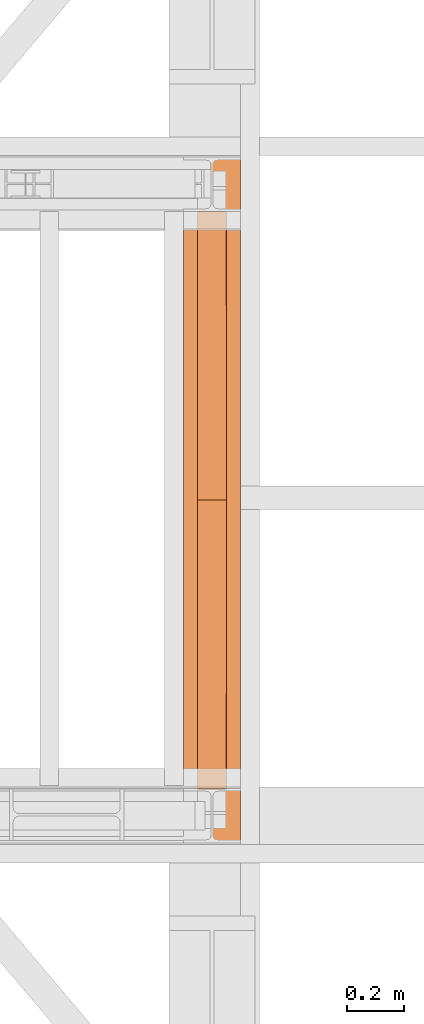
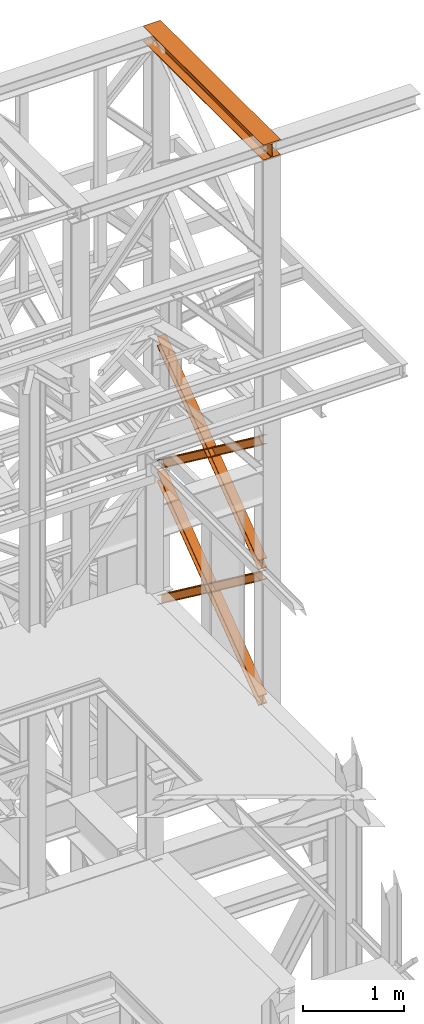
# One storey, part 183 of 208: 5 proxies.
"""IFC2X3 building model written with IfcOpenShell, lengths in millimetres."""

from ifc_helpers import new_model, entity, si_unit, converted_unit, frame, origin, origin_with_axes, place, context, subcontext, project, spatial, faceted_brep, element, save


model = new_model("IFC2X3")

# Units and contexts
model_context = context("Model", 3, precision=1e-05, world=origin())
plan_context = context("Plan", 3, precision=1e-05, world=origin())
body_context = subcontext(model_context, "Body", "Model", "MODEL_VIEW")
ifc_project = project(units=[si_unit("LENGTHUNIT", "METRE", prefix="MILLI"), converted_unit("PLANEANGLEUNIT", "DEGREE", entity("IfcPlaneAngleMeasure", 0.0174532925199433), si_unit("PLANEANGLEUNIT", "RADIAN"), dimensions=[0, 0, 0, 0, 0, 0, 0]), si_unit("AREAUNIT", "SQUARE_METRE"), si_unit("VOLUMEUNIT", "CUBIC_METRE")], contexts=[model_context, plan_context])

# Building, storey
building_placement = place(None, origin())
building = spatial("IfcBuilding", under=ifc_project, at=building_placement, CompositionType="COMPLEX")
storey_placement = place(building_placement, origin_with_axes())
storey = spatial("IfcBuildingStorey", under=building, at=storey_placement, Name="Geschoss", CompositionType="ELEMENT")

# Proxies
proxy_1_placement = place(storey_placement, frame((8693.25496703855, -16057.57439657638, 12249.99005869381), z_axis=(0.0, 0.0, 1.0), x_axis=(1.0, 0.0, 0.0)))
element("IfcBuildingElementProxy", 1, at=proxy_1_placement, inside=storey, context=body_context, shape_type="Brep", body=[
    faceted_brep([(0.00999999999839929, 2390.010012516977, 0.01000000000021828), (200.0100029802306, 2390.010012516977, 0.01000000000021828), (200.0100029802306, 2390.010012516977, 10.00999791383765), (121.2600035762771, 2390.010012516977, 10.01000536441825), (111.9441915473326, 2390.010012516977, 11.87455041170142), (105.1245498640819, 2390.010012516977, 18.69419349193595), (103.2600015571697, 2390.010012516977, 28.01000458955787), (103.2600015571697, 2390.010012516977, 162.0100153779986), (105.1245498640819, 2390.010012516977, 171.3258264756205), (111.9441915473326, 2390.010012516977, 178.145469555855), (121.2600035762771, 2390.010012516977, 180.0100146031382), (200.0100029802306, 2390.010012516977, 180.0100146031382), (200.0100029802306, 2390.010012516977, 190.0100125169756), (0.00999999999839929, 2390.010012516977, 190.0100125169756), (0.00999999999839929, 2390.010012516977, 180.0100146031382), (78.75999940395195, 2390.010012516977, 180.0100146031382), (88.07581143289644, 2390.010012516977, 178.145469555855), (94.89545311614711, 2390.010012516977, 171.3258264756205), (96.7600014230593, 2390.010012516977, 162.0100153779986), (96.7600014230593, 2390.010012516977, 28.01000458955787), (94.89545311614711, 2390.010012516977, 18.69419349193595), (88.07581143289644, 2390.010012516977, 11.87455041170142), (78.75999940395195, 2390.010012516977, 10.01000536441825), (0.00999999999839929, 2390.010012516977, 10.00999791383765), (200.0100029802306, 2390.010012516977, 0.01000000000021828), (0.00999999999839929, 2390.010012516977, 0.01000000000021828), (0.01000000000021828, 0.01000000000021828, 0.01000000000021828), (200.0100029802325, 0.01000000000021828, 0.01000000000021828), (200.0100029802306, 2390.010012516977, 10.00999791383765), (200.0100029802306, 2390.010012516977, 0.01000000000021828), (200.0100029802325, 0.01000000000021828, 0.01000000000021828), (200.0100029802325, 0.01000000000021828, 10.00999791383765), (121.2600035762771, 2390.010012516977, 10.01000536441825), (200.0100029802306, 2390.010012516977, 10.00999791383765), (200.0100029802325, 0.01000000000021828, 10.00999791383765), (121.2600035762789, 0.01000000000021828, 10.01000536441825), (111.9441915473326, 2390.010012516977, 11.87455041170142), (121.2600035762771, 2390.010012516977, 10.01000536441825), (121.2600035762789, 0.01000000000021828, 10.01000536441825), (111.9441915473344, 0.01000000000021828, 11.87455041170142), (105.1245498640819, 2390.010012516977, 18.69419349193595), (111.9441915473326, 2390.010012516977, 11.87455041170142), (111.9441915473344, 0.01000000000021828, 11.87455041170142), (105.1245498640838, 0.01000000000021828, 18.69419349193595), (103.2600015571697, 2390.010012516977, 28.01000458955787), (105.1245498640819, 2390.010012516977, 18.69419349193595), (105.1245498640838, 0.01000000000021828, 18.69419349193595), (103.2600015571716, 0.01000000000021828, 28.01000458955787), (103.2600015571697, 2390.010012516977, 162.0100153779986), (103.2600015571697, 2390.010012516977, 28.01000458955787), (103.2600015571716, 0.01000000000021828, 28.01000458955787), (103.2600015571716, 0.01000000000021828, 162.0100153779986), (105.1245498640819, 2390.010012516977, 171.3258264756205), (103.2600015571697, 2390.010012516977, 162.0100153779986), (103.2600015571716, 0.01000000000021828, 162.0100153779986), (105.1245498640838, 0.01000000000021828, 171.3258264756205), (111.9441915473326, 2390.010012516977, 178.145469555855), (105.1245498640819, 2390.010012516977, 171.3258264756205), (105.1245498640838, 0.01000000000021828, 171.3258264756205), (111.9441915473344, 0.01000000000021828, 178.145469555855), (121.2600035762771, 2390.010012516977, 180.0100146031382), (111.9441915473326, 2390.010012516977, 178.145469555855), (111.9441915473344, 0.01000000000021828, 178.145469555855), (121.2600035762789, 0.01000000000021828, 180.0100146031382), (200.0100029802306, 2390.010012516977, 180.0100146031382), (121.2600035762771, 2390.010012516977, 180.0100146031382), (121.2600035762789, 0.01000000000021828, 180.0100146031382), (200.0100029802325, 0.01000000000021828, 180.0100146031382), (200.0100029802306, 2390.010012516977, 190.0100125169756), (200.0100029802306, 2390.010012516977, 180.0100146031382), (200.0100029802325, 0.01000000000021828, 180.0100146031382), (200.0100029802325, 0.01000000000021828, 190.0100125169756), (0.00999999999839929, 2390.010012516977, 190.0100125169756), (200.0100029802306, 2390.010012516977, 190.0100125169756), (200.0100029802325, 0.01000000000021828, 190.0100125169756), (0.01000000000021828, 0.01000000000021828, 190.0100125169756), (0.00999999999839929, 2390.010012516977, 180.0100146031382), (0.00999999999839929, 2390.010012516977, 190.0100125169756), (0.01000000000021828, 0.01000000000021828, 190.0100125169756), (0.01000000000021828, 0.01000000000021828, 180.0100146031382), (78.75999940395195, 2390.010012516977, 180.0100146031382), (0.00999999999839929, 2390.010012516977, 180.0100146031382), (0.01000000000021828, 0.01000000000021828, 180.0100146031382), (78.75999940395377, 0.01000000000021828, 180.0100146031382), (88.07581143289644, 2390.010012516977, 178.145469555855), (78.75999940395195, 2390.010012516977, 180.0100146031382), (78.75999940395377, 0.01000000000021828, 180.0100146031382), (88.07581143289826, 0.01000000000021828, 178.145469555855), (94.89545311614711, 2390.010012516977, 171.3258264756205), (88.07581143289644, 2390.010012516977, 178.145469555855), (88.07581143289826, 0.01000000000021828, 178.145469555855), (94.89545311614893, 0.01000000000021828, 171.3258264756205), (96.7600014230593, 2390.010012516977, 162.0100153779986), (94.89545311614711, 2390.010012516977, 171.3258264756205), (94.89545311614893, 0.01000000000021828, 171.3258264756205), (96.76000142306111, 0.01000000000021828, 162.0100153779986), (96.7600014230593, 2390.010012516977, 28.01000458955787), (96.7600014230593, 2390.010012516977, 162.0100153779986), (96.76000142306111, 0.01000000000021828, 162.0100153779986), (96.76000142306111, 0.01000000000021828, 28.01000458955787), (94.89545311614711, 2390.010012516977, 18.69419349193595), (96.7600014230593, 2390.010012516977, 28.01000458955787), (96.76000142306111, 0.01000000000021828, 28.01000458955787), (94.89545311614893, 0.01000000000021828, 18.69419349193595), (88.07581143289644, 2390.010012516977, 11.87455041170142), (94.89545311614711, 2390.010012516977, 18.69419349193595), (94.89545311614893, 0.01000000000021828, 18.69419349193595), (88.07581143289826, 0.01000000000021828, 11.87455041170142), (78.75999940395195, 2390.010012516977, 10.01000536441825), (88.07581143289644, 2390.010012516977, 11.87455041170142), (88.07581143289826, 0.01000000000021828, 11.87455041170142), (78.75999940395377, 0.01000000000021828, 10.01000536441825), (0.00999999999839929, 2390.010012516977, 10.00999791383765), (78.75999940395195, 2390.010012516977, 10.01000536441825), (78.75999940395377, 0.01000000000021828, 10.01000536441825), (0.01000000000021828, 0.01000000000021828, 10.00999791383765), (0.00999999999839929, 2390.010012516977, 0.01000000000021828), (0.00999999999839929, 2390.010012516977, 10.00999791383765), (0.01000000000021828, 0.01000000000021828, 10.00999791383765), (0.01000000000021828, 0.01000000000021828, 0.01000000000021828), (0.01000000000021828, 0.01000000000021828, 0.01000000000021828), (0.01000000000021828, 0.01000000000021828, 10.00999791383765), (78.75999940395377, 0.01000000000021828, 10.01000536441825), (88.07581143289826, 0.01000000000021828, 11.87455041170142), (94.89545311614893, 0.01000000000021828, 18.69419349193595), (96.76000142306111, 0.01000000000021828, 28.01000458955787), (96.76000142306111, 0.01000000000021828, 162.0100153779986), (94.89545311614893, 0.01000000000021828, 171.3258264756205), (88.07581143289826, 0.01000000000021828, 178.145469555855), (78.75999940395377, 0.01000000000021828, 180.0100146031382), (0.01000000000021828, 0.01000000000021828, 180.0100146031382), (0.01000000000021828, 0.01000000000021828, 190.0100125169756), (200.0100029802325, 0.01000000000021828, 190.0100125169756), (200.0100029802325, 0.01000000000021828, 180.0100146031382), (121.2600035762789, 0.01000000000021828, 180.0100146031382), (111.9441915473344, 0.01000000000021828, 178.145469555855), (105.1245498640838, 0.01000000000021828, 171.3258264756205), (103.2600015571716, 0.01000000000021828, 162.0100153779986), (103.2600015571716, 0.01000000000021828, 28.01000458955787), (105.1245498640838, 0.01000000000021828, 18.69419349193595), (111.9441915473344, 0.01000000000021828, 11.87455041170142), (121.2600035762789, 0.01000000000021828, 10.01000536441825), (200.0100029802325, 0.01000000000021828, 10.00999791383765), (200.0100029802325, 0.01000000000021828, 0.01000000000021828)], [[[0, 1, 2, 3, 4, 5, 6, 7, 8, 9, 10, 11, 12, 13, 14, 15, 16, 17, 18, 19, 20, 21, 22, 23]], [[24, 25, 26, 27]], [[28, 29, 30, 31]], [[32, 33, 34, 35]], [[36, 37, 38, 39]], [[40, 41, 42, 43]], [[44, 45, 46, 47]], [[48, 49, 50, 51]], [[52, 53, 54, 55]], [[56, 57, 58, 59]], [[60, 61, 62, 63]], [[64, 65, 66, 67]], [[68, 69, 70, 71]], [[72, 73, 74, 75]], [[76, 77, 78, 79]], [[80, 81, 82, 83]], [[84, 85, 86, 87]], [[88, 89, 90, 91]], [[92, 93, 94, 95]], [[96, 97, 98, 99]], [[100, 101, 102, 103]], [[104, 105, 106, 107]], [[108, 109, 110, 111]], [[112, 113, 114, 115]], [[116, 117, 118, 119]], [[120, 121, 122, 123, 124, 125, 126, 127, 128, 129, 130, 131, 132, 133, 134, 135, 136, 137, 138, 139, 140, 141, 142, 143]]], orient=[[False], [False], [False], [False], [False], [False], [False], [False], [False], [False], [False], [False], [False], [False], [False], [False], [False], [False], [False], [False], [False], [False], [False], [False], [False], [False]]),
])
proxy_2_placement = place(storey_placement, frame((8743.082798491103, -15873.1965123697, 5499.689768811883), z_axis=(0.0, 0.0, 1.0), x_axis=(1.0, 0.0, 0.0)))
element("IfcBuildingElementProxy", 2, at=proxy_2_placement, inside=storey, context=body_context, shape_type="Brep", body=[
    faceted_brep([(100.0229428112289, 2015.632115793322, 1505.703241650141), (100.1858455764686, 1.953628280809426, 0.02100513656296243), (100.1847800613887, 1.791659257409265, 9.702984703128095), (100.0218641931642, 2015.632115793322, 1515.50632986583), (0.02294341679771605, 2015.632115793322, 1505.692236513578), (0.1858461820338562, 1.953628280809426, 0.01000000000021828), (100.1858455764686, 1.953628280809426, 0.02100513656296243), (100.0229428112289, 2015.632115793322, 1505.703241650141), (0.02186479873125791, 2015.632115793322, 1515.495324729271), (0.1847806669538841, 1.791659257407446, 9.691979566568989), (0.1858461820338562, 1.953628280809426, 0.01000000000021828), (0.02294341679771605, 2015.632115793322, 1505.692236513578), (47.52186451108355, 2015.632115793322, 1515.500552169136), (47.68478037930981, 1.791659257407446, 9.697207006434837), (0.1847806669538841, 1.791659257407446, 9.691979566568989), (0.02186479873125791, 2015.632115793322, 1515.495324729271), (47.51107833042624, 2015.632115793322, 1613.531434326045), (47.67412522851737, 0.1719690234003792, 106.517002672068), (47.68478037930981, 1.791659257407446, 9.697207006434837), (47.52186451108355, 2015.632115793322, 1515.500552169136), (0.01107861806849542, 2015.632115793322, 1613.526206886179), (0.174125516157801, 0.1719690234003792, 106.5117752322021), (47.67412522851737, 0.1719690234003792, 106.517002672068), (47.51107833042624, 2015.632115793322, 1613.531434326045), (0.01000000000021828, 2015.632115793322, 1623.329295101868), (0.1730600010778289, 0.01000000000021828, 116.1937547987636), (0.174125516157801, 0.1719690234003792, 106.5117752322021), (0.01107861806849542, 2015.632115793322, 1613.526206886179), (100.0099993944386, 2015.632115793322, 1623.340300238435), (100.1730593955126, 0.01000000000203727, 116.2047599353264), (0.1730600010778289, 0.01000000000021828, 116.1937547987636), (0.01000000000021828, 2015.632115793322, 1623.329295101868), (100.0110780125051, 2015.632115793322, 1613.537212022739), (100.1741249105908, 0.1719690234003792, 106.5227803687612), (100.1730593955126, 0.01000000000203727, 116.2047599353264), (100.0099993944386, 2015.632115793322, 1623.340300238435), (52.51107830014917, 2015.632115793322, 1613.531984582873), (52.67412519823665, 0.1719690234003792, 106.5175529288954), (100.1741249105908, 0.1719690234003792, 106.5227803687612), (100.0110780125051, 2015.632115793322, 1613.537212022739), (52.52186448080829, 2015.632115793322, 1515.501102425964), (52.68478034903274, 1.791659257409265, 9.697757263262247), (52.67412519823665, 0.1719690234003792, 106.5175529288954), (52.51107830014917, 2015.632115793322, 1613.531984582873), (100.0218641931642, 2015.632115793322, 1515.50632986583), (100.1847800613887, 1.791659257409265, 9.702984703128095), (52.68478034903274, 1.791659257409265, 9.697757263262247), (52.52186448080829, 2015.632115793322, 1515.501102425964), (100.1858455764686, 1.953628280809426, 0.02100513656296243), (0.1858461820338562, 1.953628280809426, 0.01000000000021828), (0.1847806669538841, 1.791659257407446, 9.691979566568989), (47.68478037930981, 1.791659257407446, 9.697207006434837), (47.67412522851737, 0.1719690234003792, 106.517002672068), (0.174125516157801, 0.1719690234003792, 106.5117752322021), (0.1730600010778289, 0.01000000000021828, 116.1937547987636), (100.1730593955126, 0.01000000000203727, 116.2047599353264), (100.1741249105908, 0.1719690234003792, 106.5227803687612), (52.67412519823665, 0.1719690234003792, 106.5175529288954), (52.68478034903274, 1.791659257409265, 9.697757263262247), (100.1847800613887, 1.791659257409265, 9.702984703128095), (100.0218641931642, 2015.632115793322, 1515.50632986583), (52.52186448080829, 2015.632115793322, 1515.501102425964), (52.51107830014917, 2015.632115793322, 1613.531984582873), (100.0110780125051, 2015.632115793322, 1613.537212022739), (100.0099993944386, 2015.632115793322, 1623.340300238435), (0.01000000000021828, 2015.632115793322, 1623.329295101868), (0.01107861806849542, 2015.632115793322, 1613.526206886179), (47.51107833042624, 2015.632115793322, 1613.531434326045), (47.52186451108355, 2015.632115793322, 1515.500552169136), (0.02186479873125791, 2015.632115793322, 1515.495324729271), (0.02294341679771605, 2015.632115793322, 1505.692236513578), (100.0229428112289, 2015.632115793322, 1505.703241650141)], [[[0, 1, 2, 3]], [[4, 5, 6, 7]], [[8, 9, 10, 11]], [[12, 13, 14, 15]], [[16, 17, 18, 19]], [[20, 21, 22, 23]], [[24, 25, 26, 27]], [[28, 29, 30, 31]], [[32, 33, 34, 35]], [[36, 37, 38, 39]], [[40, 41, 42, 43]], [[44, 45, 46, 47]], [[48, 49, 50, 51, 52, 53, 54, 55, 56, 57, 58, 59]], [[60, 61, 62, 63, 64, 65, 66, 67, 68, 69, 70, 71]]], orient=[[False], [False], [False], [False], [False], [False], [False], [False], [False], [False], [False], [False], [False], [False]]),
])
proxy_3_placement = place(storey_placement, frame((8743.082676642578, -15867.5743840594, 5504.219540188055), z_axis=(0.0, 0.0, 1.0), x_axis=(1.0, 0.0, 0.0)))
element("IfcBuildingElementProxy", 3, at=proxy_3_placement, inside=storey, context=body_context, shape_type="Brep", body=[
    faceted_brep([(100.0218596475406, 0.01000000000021828, 1511.076608371926), (100.1844513161013, 2010.009987483025, 9.820176864343011), (100.1855295209298, 2010.009987483025, 0.02100513655932446), (100.0229378523673, 0.01000000000021828, 1501.277436644132), (100.0229378523673, 0.01000000000021828, 1501.277436644132), (100.1855295209298, 2010.009987483025, 0.02100513655932446), (0.1855301264913578, 2010.009987483025, 0.01000000000021828), (0.02293845793246874, 0.01000000000021828, 1501.266431507576), (0.02293845793246874, 0.01000000000021828, 1501.266431507576), (0.1855301264913578, 2010.009987483025, 0.01000000000021828), (0.1844519216665503, 2010.009987483025, 9.809171727787543), (0.02186025310402329, 0.01000000000021828, 1511.06560323536), (0.02186025310402329, 0.01000000000021828, 1511.06560323536), (0.1844519216665503, 2010.009987483025, 9.809171727787543), (47.6844516340243, 2010.009987483025, 9.814399167646116), (47.52185996546359, 0.01000000000021828, 1511.070830675226), (47.52185996546359, 0.01000000000021828, 1511.070830675226), (47.6844516340243, 2010.009987483025, 9.814399167646116), (47.6736695857453, 2010.009987483025, 107.8061164454975), (47.51107791718459, 0.01000000000021828, 1609.062547953077), (47.51107791718459, 0.01000000000021828, 1609.062547953077), (47.6736695857453, 2010.009987483025, 107.8061164454975), (0.1736698733893718, 2010.009987483025, 107.8008890056317), (0.01107820482866373, 0.01000000000021828, 1609.057320513211), (0.01107820482866373, 0.01000000000021828, 1609.057320513211), (0.1736698733893718, 2010.009987483025, 107.8008890056317), (0.1725916685609263, 2010.009987483025, 117.6000607334227), (0.01000000000021828, 0.01000000000021828, 1618.856492240995), (0.01000000000021828, 0.01000000000021828, 1618.856492240995), (0.1725916685609263, 2010.009987483025, 117.6000607334227), (100.1725910629975, 2010.009987483025, 117.6110658699781), (100.009999394435, 0.01000000000021828, 1618.867497377558), (100.009999394435, 0.01000000000021828, 1618.867497377558), (100.1725910629975, 2010.009987483025, 117.6110658699781), (100.1736692678242, 2010.009987483025, 107.8118941421981), (100.0110775992634, 0.01000000000021828, 1609.068325649774), (100.0110775992634, 0.01000000000021828, 1609.068325649774), (100.1736692678242, 2010.009987483025, 107.8118941421981), (52.67366955546459, 2010.009987483025, 107.806666702325), (52.51107788690388, 0.01000000000021828, 1609.063098209905), (52.51107788690388, 0.01000000000021828, 1609.063098209905), (52.67366955546459, 2010.009987483025, 107.806666702325), (52.6844516037454, 2010.009987483025, 9.814949424477163), (52.52185993518287, 0.01000000000021828, 1511.071380932057), (52.52185993518287, 0.01000000000021828, 1511.071380932057), (52.6844516037454, 2010.009987483025, 9.814949424477163), (100.1844513161013, 2010.009987483025, 9.820176864343011), (100.0218596475406, 0.01000000000021828, 1511.076608371926), (100.1844513161013, 2010.009987483025, 9.820176864343011), (52.6844516037454, 2010.009987483025, 9.814949424477163), (52.67366955546459, 2010.009987483025, 107.806666702325), (100.1736692678242, 2010.009987483025, 107.8118941421981), (100.1725910629975, 2010.009987483025, 117.6110658699781), (0.1725916685609263, 2010.009987483025, 117.6000607334227), (0.1736698733893718, 2010.009987483025, 107.8008890056317), (47.6736695857453, 2010.009987483025, 107.8061164454975), (47.6844516340243, 2010.009987483025, 9.814399167646116), (0.1844519216665503, 2010.009987483025, 9.809171727787543), (0.1855301264913578, 2010.009987483025, 0.01000000000021828), (100.1855295209298, 2010.009987483025, 0.02100513655932446), (100.0229378523673, 0.01000000000021828, 1501.277436644132), (0.02293845793246874, 0.01000000000021828, 1501.266431507576), (0.02186025310402329, 0.01000000000021828, 1511.06560323536), (47.52185996546359, 0.01000000000021828, 1511.070830675226), (47.51107791718459, 0.01000000000021828, 1609.062547953077), (0.01107820482866373, 0.01000000000021828, 1609.057320513211), (0.01000000000021828, 0.01000000000021828, 1618.856492240995), (100.009999394435, 0.01000000000021828, 1618.867497377558), (100.0110775992634, 0.01000000000021828, 1609.068325649774), (52.51107788690388, 0.01000000000021828, 1609.063098209905), (52.52185993518287, 0.01000000000021828, 1511.071380932057), (100.0218596475406, 0.01000000000021828, 1511.076608371926)], [[[0, 1, 2, 3]], [[4, 5, 6, 7]], [[8, 9, 10, 11]], [[12, 13, 14, 15]], [[16, 17, 18, 19]], [[20, 21, 22, 23]], [[24, 25, 26, 27]], [[28, 29, 30, 31]], [[32, 33, 34, 35]], [[36, 37, 38, 39]], [[40, 41, 42, 43]], [[44, 45, 46, 47]], [[48, 49, 50, 51, 52, 53, 54, 55, 56, 57, 58, 59]], [[60, 61, 62, 63, 64, 65, 66, 67, 68, 69, 70, 71]]], orient=[[False], [False], [False], [False], [False], [False], [False], [False], [False], [False], [False], [False], [False], [False]]),
])
proxy_4_placement = place(storey_placement, frame((8742.895475356378, -15867.5743840594, 7147.441290649187), z_axis=(0.0, 0.0, 1.0), x_axis=(1.0, 0.0, 0.0)))
element("IfcBuildingElementProxy", 4, at=proxy_4_placement, inside=storey, context=body_context, shape_type="Brep", body=[
    faceted_brep([(100.0218623025594, 0.01000000000021828, 1512.063556389601), (100.1844166626888, 2010.009987483025, 9.822513400360549), (100.1854951088844, 2010.009987483025, 0.02100513655932446), (100.0229407487532, 0.01000000000021828, 1502.262048125804), (100.0229407487532, 0.01000000000021828, 1502.262048125804), (100.1854951088844, 2010.009987483025, 0.02100513655932446), (0.1854957144496439, 2010.009987483025, 0.01000000000021828), (0.02294135431657196, 0.01000000000021828, 1502.251042989237), (0.02294135431657196, 0.01000000000021828, 1502.251042989237), (0.1854957144496439, 2010.009987483025, 0.01000000000021828), (0.1844172682540375, 2010.009987483025, 9.811508263797805), (0.02186290812460356, 0.01000000000021828, 1512.052551253039), (0.02186290812460356, 0.01000000000021828, 1512.052551253039), (0.1844172682540375, 2010.009987483025, 9.811508263797805), (47.68441698061179, 2010.009987483025, 9.816735703663653), (47.52186262048053, 0.01000000000021828, 1512.057778692908), (47.52186262048053, 0.01000000000021828, 1512.057778692908), (47.68441698061179, 2010.009987483025, 9.816735703663653), (47.67363251868301, 2010.009987483025, 107.8318183416577), (47.51107815854994, 0.01000000000021828, 1610.072861330906), (47.51107815854994, 0.01000000000021828, 1610.072861330906), (47.67363251868301, 2010.009987483025, 107.8318183416577), (0.1736328063234396, 2010.009987483025, 107.8265909017955), (0.01107844619400566, 0.01000000000021828, 1610.067633891033), (0.01107844619400566, 0.01000000000021828, 1610.067633891033), (0.1736328063234396, 2010.009987483025, 107.8265909017955), (0.1725543601296522, 2010.009987483025, 117.6280991655931), (0.00999999999839929, 0.01000000000021828, 1619.86914215483), (0.00999999999839929, 0.01000000000021828, 1619.86914215483), (0.1725543601296522, 2010.009987483025, 117.6280991655931), (100.1725537545644, 2010.009987483025, 117.6391043021558), (100.0099993944332, 0.01000000000021828, 1619.880147291397), (100.0099993944332, 0.01000000000021828, 1619.880147291397), (100.1725537545644, 2010.009987483025, 117.6391043021558), (100.17363220076, 2010.009987483025, 107.8375960383546), (100.0110778406288, 0.01000000000021828, 1610.078639027603), (100.0110778406288, 0.01000000000021828, 1610.078639027603), (100.17363220076, 2010.009987483025, 107.8375960383546), (52.67363248840229, 2010.009987483025, 107.8323685984888), (52.51107812827286, 0.01000000000021828, 1610.073411587733), (52.51107812827286, 0.01000000000021828, 1610.073411587733), (52.67363248840229, 2010.009987483025, 107.8323685984888), (52.68441695033289, 2010.009987483025, 9.817285960491063), (52.52186259020164, 0.01000000000021828, 1512.058328949732), (52.52186259020164, 0.01000000000021828, 1512.058328949732), (52.68441695033289, 2010.009987483025, 9.817285960491063), (100.1844166626888, 2010.009987483025, 9.822513400360549), (100.0218623025594, 0.01000000000021828, 1512.063556389601), (100.1844166626888, 2010.009987483025, 9.822513400360549), (52.68441695033289, 2010.009987483025, 9.817285960491063), (52.67363248840229, 2010.009987483025, 107.8323685984888), (100.17363220076, 2010.009987483025, 107.8375960383546), (100.1725537545644, 2010.009987483025, 117.6391043021558), (0.1725543601296522, 2010.009987483025, 117.6280991655931), (0.1736328063234396, 2010.009987483025, 107.8265909017955), (47.67363251868301, 2010.009987483025, 107.8318183416577), (47.68441698061179, 2010.009987483025, 9.816735703663653), (0.1844172682540375, 2010.009987483025, 9.811508263797805), (0.1854957144496439, 2010.009987483025, 0.01000000000021828), (100.1854951088844, 2010.009987483025, 0.02100513655932446), (100.0229407487532, 0.01000000000021828, 1502.262048125804), (0.02294135431657196, 0.01000000000021828, 1502.251042989237), (0.02186290812460356, 0.01000000000021828, 1512.052551253039), (47.52186262048053, 0.01000000000021828, 1512.057778692908), (47.51107815854994, 0.01000000000021828, 1610.072861330906), (0.01107844619400566, 0.01000000000021828, 1610.067633891033), (0.00999999999839929, 0.01000000000021828, 1619.86914215483), (100.0099993944332, 0.01000000000021828, 1619.880147291397), (100.0110778406288, 0.01000000000021828, 1610.078639027603), (52.51107812827286, 0.01000000000021828, 1610.073411587733), (52.52186259020164, 0.01000000000021828, 1512.058328949732), (100.0218623025594, 0.01000000000021828, 1512.063556389601)], [[[0, 1, 2, 3]], [[4, 5, 6, 7]], [[8, 9, 10, 11]], [[12, 13, 14, 15]], [[16, 17, 18, 19]], [[20, 21, 22, 23]], [[24, 25, 26, 27]], [[28, 29, 30, 31]], [[32, 33, 34, 35]], [[36, 37, 38, 39]], [[40, 41, 42, 43]], [[44, 45, 46, 47]], [[48, 49, 50, 51, 52, 53, 54, 55, 56, 57, 58, 59]], [[60, 61, 62, 63, 64, 65, 66, 67, 68, 69, 70, 71]]], orient=[[False], [False], [False], [False], [False], [False], [False], [False], [False], [False], [False], [False], [False], [False]]),
])
proxy_5_placement = place(storey_placement, frame((8742.895647595431, -15867.5743840594, 7147.394064575148), z_axis=(0.0, 0.0, 1.0), x_axis=(1.0, 0.0, 0.0)))
element("IfcBuildingElementProxy", 5, at=proxy_5_placement, inside=storey, context=body_context, shape_type="Brep", body=[
    faceted_brep([(100.0229386519495, 2010.009987483025, 1501.524522111415), (100.1855729074941, 0.01000000000021828, 0.02100513656296243), (100.1844946360343, 0.01000000000021828, 9.82075546136366), (100.0218603804897, 2010.009987483025, 1511.324272436212), (0.0229392575147358, 2010.009987483025, 1501.513516974852), (0.185573513057534, 0.01000000000021828, 0.01000000000021828), (100.1855729074941, 0.01000000000021828, 0.02100513656296243), (100.0229386519495, 2010.009987483025, 1501.524522111415), (0.02186098605307052, 2010.009987483025, 1511.313267299649), (0.1844952415976877, 0.01000000000021828, 9.809750324800916), (0.185573513057534, 0.01000000000021828, 0.01000000000021828), (0.0229392575147358, 2010.009987483025, 1501.513516974852), (47.52186069841082, 2010.009987483025, 1511.318494739518), (47.68449495395362, 0.01000000000021828, 9.814977764666764), (0.1844952415976877, 0.01000000000021828, 9.809750324800916), (0.02186098605307052, 2010.009987483025, 1511.313267299649), (47.51107798381236, 2010.009987483025, 1609.315997987507), (47.67371223935879, 0.01000000000021828, 107.8124810126556), (47.68449495395362, 0.01000000000021828, 9.814977764666764), (47.52186069841082, 2010.009987483025, 1511.318494739518), (0.01107827145824558, 2010.009987483025, 1609.310770547641), (0.1737125270010438, 0.01000000000021828, 107.8072535727861), (47.67371223935879, 0.01000000000021828, 107.8124810126556), (47.51107798381236, 2010.009987483025, 1609.315997987507), (0.00999999999839929, 2010.009987483025, 1619.110520872438), (0.1726342555430165, 0.01000000000021828, 117.6070038975868), (0.1737125270010438, 0.01000000000021828, 107.8072535727861), (0.01107827145824558, 2010.009987483025, 1609.310770547641), (100.0099993944332, 2010.009987483025, 1619.121526009001), (100.172633649976, 0.01000000000021828, 117.6180090341495), (0.1726342555430165, 0.01000000000021828, 117.6070038975868), (0.00999999999839929, 2010.009987483025, 1619.110520872438), (100.011077665893, 2010.009987483025, 1609.321775684197), (100.1737119214358, 0.01000000000021828, 107.8182587093452), (100.172633649976, 0.01000000000021828, 117.6180090341495), (100.0099993944332, 2010.009987483025, 1619.121526009001), (52.51107795353528, 2010.009987483025, 1609.316548244331), (52.67371220908171, 0.01000000000021828, 107.8130312694793), (100.1737119214358, 0.01000000000021828, 107.8182587093452), (100.011077665893, 2010.009987483025, 1609.321775684197), (52.52186066813192, 2010.009987483025, 1511.319044996339), (52.68449492367836, 0.01000000000021828, 9.815528021497812), (52.67371220908171, 0.01000000000021828, 107.8130312694793), (52.51107795353528, 2010.009987483025, 1609.316548244331), (100.0218603804897, 2010.009987483025, 1511.324272436212), (100.1844946360343, 0.01000000000021828, 9.82075546136366), (52.68449492367836, 0.01000000000021828, 9.815528021497812), (52.52186066813192, 2010.009987483025, 1511.319044996339), (100.1855729074941, 0.01000000000021828, 0.02100513656296243), (0.185573513057534, 0.01000000000021828, 0.01000000000021828), (0.1844952415976877, 0.01000000000021828, 9.809750324800916), (47.68449495395362, 0.01000000000021828, 9.814977764666764), (47.67371223935879, 0.01000000000021828, 107.8124810126556), (0.1737125270010438, 0.01000000000021828, 107.8072535727861), (0.1726342555430165, 0.01000000000021828, 117.6070038975868), (100.172633649976, 0.01000000000021828, 117.6180090341495), (100.1737119214358, 0.01000000000021828, 107.8182587093452), (52.67371220908171, 0.01000000000021828, 107.8130312694793), (52.68449492367836, 0.01000000000021828, 9.815528021497812), (100.1844946360343, 0.01000000000021828, 9.82075546136366), (100.0218603804897, 2010.009987483025, 1511.324272436212), (52.52186066813192, 2010.009987483025, 1511.319044996339), (52.51107795353528, 2010.009987483025, 1609.316548244331), (100.011077665893, 2010.009987483025, 1609.321775684197), (100.0099993944332, 2010.009987483025, 1619.121526009001), (0.00999999999839929, 2010.009987483025, 1619.110520872438), (0.01107827145824558, 2010.009987483025, 1609.310770547641), (47.51107798381236, 2010.009987483025, 1609.315997987507), (47.52186069841082, 2010.009987483025, 1511.318494739518), (0.02186098605307052, 2010.009987483025, 1511.313267299649), (0.0229392575147358, 2010.009987483025, 1501.513516974852), (100.0229386519495, 2010.009987483025, 1501.524522111415)], [[[0, 1, 2, 3]], [[4, 5, 6, 7]], [[8, 9, 10, 11]], [[12, 13, 14, 15]], [[16, 17, 18, 19]], [[20, 21, 22, 23]], [[24, 25, 26, 27]], [[28, 29, 30, 31]], [[32, 33, 34, 35]], [[36, 37, 38, 39]], [[40, 41, 42, 43]], [[44, 45, 46, 47]], [[48, 49, 50, 51, 52, 53, 54, 55, 56, 57, 58, 59]], [[60, 61, 62, 63, 64, 65, 66, 67, 68, 69, 70, 71]]], orient=[[False], [False], [False], [False], [False], [False], [False], [False], [False], [False], [False], [False], [False], [False]]),
])

save(model, "model.ifc")
